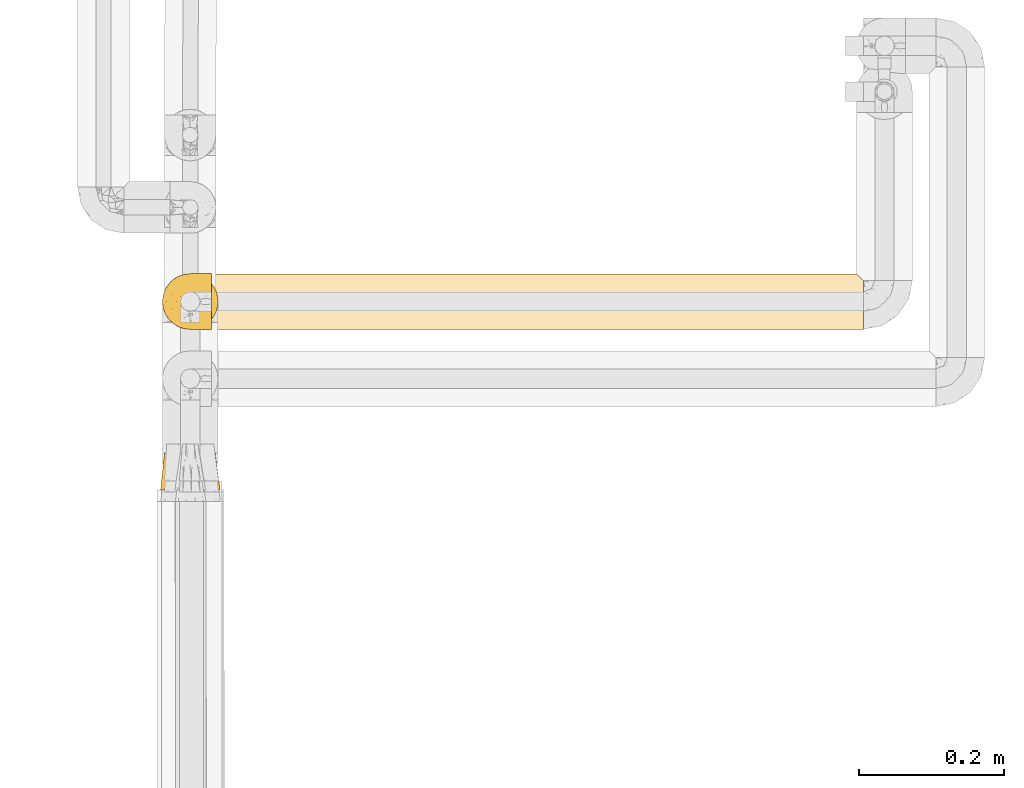
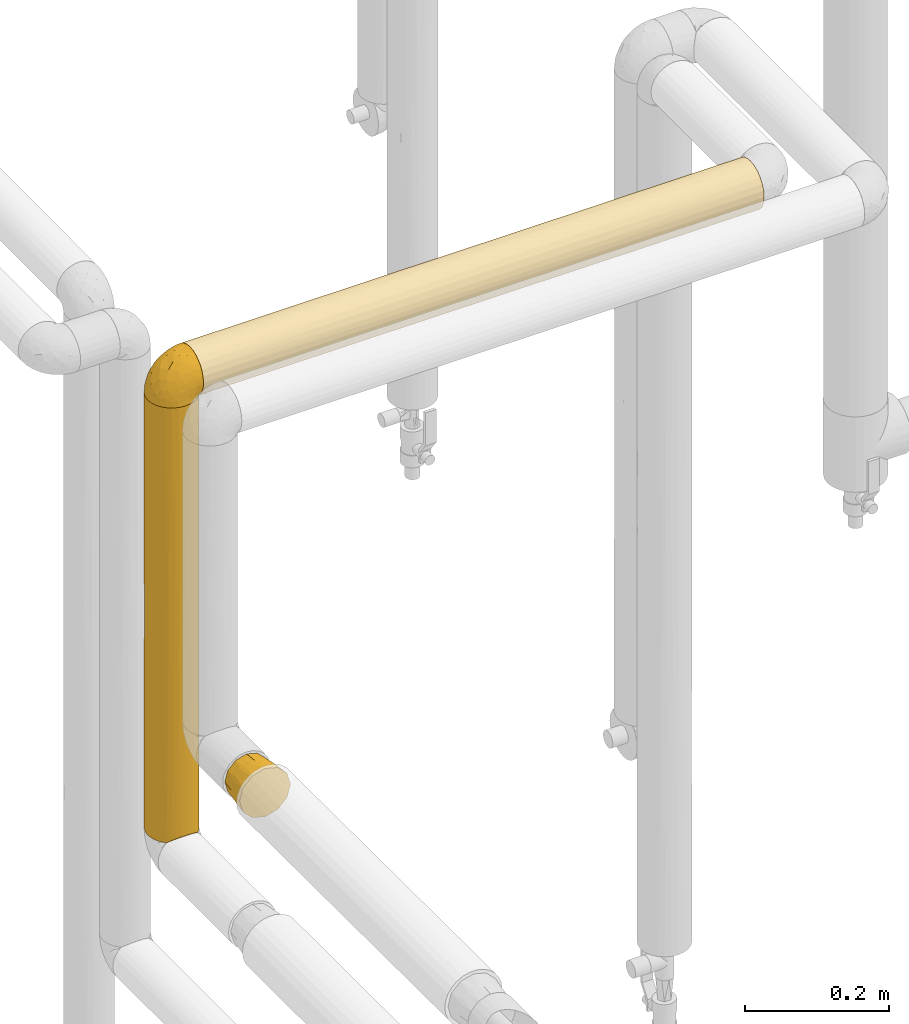
# One storey, part 77 of 827: 4 coverings.
"""IFC2X3 building model written with IfcOpenShell, lengths in millimetres."""

from ifc_helpers import new_model, entity, si_unit, converted_unit, derived_unit, direction, frame, origin, place, context, subcontext, project, spatial, faceted_brep, element, save


model = new_model("IFC2X3")

# Units and contexts
model_context = context("Model", 3, precision=0.01, world=origin(), true_north=direction((6.12303176911189e-17, 1.0)))
body_context = subcontext(model_context, "Body", "Model", "MODEL_VIEW")
ifc_project = project(units=[si_unit("LENGTHUNIT", "METRE", prefix="MILLI"), si_unit("AREAUNIT", "SQUARE_METRE"), si_unit("VOLUMEUNIT", "CUBIC_METRE"), converted_unit("PLANEANGLEUNIT", "DEGREE", entity("IfcRatioMeasure", 0.0174532925199433), si_unit("PLANEANGLEUNIT", "RADIAN"), dimensions=[0, 0, 0, 0, 0, 0, 0]), si_unit("MASSUNIT", "GRAM", prefix="KILO"), derived_unit("MASSDENSITYUNIT", [(si_unit("MASSUNIT", "GRAM", prefix="KILO"), 1), (si_unit("LENGTHUNIT", "METRE"), -3)]), derived_unit("MOMENTOFINERTIAUNIT", [(si_unit("LENGTHUNIT", "METRE"), 4)]), si_unit("TIMEUNIT", "SECOND"), si_unit("FREQUENCYUNIT", "HERTZ"), si_unit("THERMODYNAMICTEMPERATUREUNIT", "DEGREE_CELSIUS"), derived_unit("THERMALTRANSMITTANCEUNIT", [(si_unit("MASSUNIT", "GRAM", prefix="KILO"), 1), (si_unit("THERMODYNAMICTEMPERATUREUNIT", "KELVIN"), -1), (si_unit("TIMEUNIT", "SECOND"), -3)]), derived_unit("VOLUMETRICFLOWRATEUNIT", [(si_unit("LENGTHUNIT", "METRE"), 3), (si_unit("TIMEUNIT", "SECOND"), -1)]), derived_unit("MASSFLOWRATEUNIT", [(si_unit("MASSUNIT", "GRAM", prefix="KILO"), 1), (si_unit("TIMEUNIT", "SECOND"), -1)]), derived_unit("ROTATIONALFREQUENCYUNIT", [(si_unit("TIMEUNIT", "SECOND"), -1)]), si_unit("ELECTRICCURRENTUNIT", "AMPERE"), si_unit("ELECTRICVOLTAGEUNIT", "VOLT"), si_unit("POWERUNIT", "WATT"), si_unit("FORCEUNIT", "NEWTON", prefix="KILO"), si_unit("ILLUMINANCEUNIT", "LUX"), si_unit("LUMINOUSFLUXUNIT", "LUMEN"), si_unit("LUMINOUSINTENSITYUNIT", "CANDELA"), derived_unit("USERDEFINED", [(si_unit("MASSUNIT", "GRAM", prefix="KILO"), -1), (si_unit("LENGTHUNIT", "METRE"), -2), (si_unit("TIMEUNIT", "SECOND"), 3), (si_unit("LUMINOUSFLUXUNIT", "LUMEN"), 1)]), derived_unit("LINEARVELOCITYUNIT", [(si_unit("LENGTHUNIT", "METRE"), 1), (si_unit("TIMEUNIT", "SECOND"), -1)]), si_unit("PRESSUREUNIT", "PASCAL"), derived_unit("USERDEFINED", [(si_unit("LENGTHUNIT", "METRE"), -2), (si_unit("MASSUNIT", "GRAM", prefix="KILO"), 1), (si_unit("TIMEUNIT", "SECOND"), -2)]), derived_unit("LINEARFORCEUNIT", [(si_unit("MASSUNIT", "GRAM", prefix="KILO"), 1), (si_unit("LENGTHUNIT", "METRE"), 1), (si_unit("TIMEUNIT", "SECOND"), -2), (si_unit("LENGTHUNIT", "METRE"), -1)]), derived_unit("PLANARFORCEUNIT", [(si_unit("MASSUNIT", "GRAM", prefix="KILO"), 1), (si_unit("LENGTHUNIT", "METRE"), 1), (si_unit("TIMEUNIT", "SECOND"), -2), (si_unit("LENGTHUNIT", "METRE"), -2)])], contexts=[model_context])

# Site, building, storey
site_placement = place(None, origin())
site = spatial("IfcSite", under=ifc_project, at=site_placement, CompositionType="ELEMENT")
building_placement = place(site_placement, origin())
building = spatial("IfcBuilding", under=site, at=building_placement, CompositionType="ELEMENT")
storey_placement = place(building_placement, frame((0.0, 0.0, 28200.0)))
storey = spatial("IfcBuildingStorey", under=building, at=storey_placement, Name="08", CompositionType="ELEMENT", Elevation=28200.0)

# Coverings
covering_1_placement = place(storey_placement, frame((17884.13, 11605.87, 1305.65)))
element("IfcCovering", 1, at=covering_1_placement, inside=storey, Name=":ADSK_", ObjectType=":ADSK_", PredefinedType="INSULATION", context=body_context, shape_type="Brep", body=[
    faceted_brep([(74.78, 51.25, 51.35), (77.13, 51.26, 42.6), (74.78, 51.25, 33.85), (72.44, 51.24, 25.1), (66.03, 51.22, 18.69), (59.63, 51.2, 12.28), (50.88, 51.17, 9.94), (42.13, 51.14, 7.6), (33.38, 51.11, 9.94), (24.63, 51.08, 12.28), (18.22, 51.06, 18.69), (11.82, 51.04, 25.1), (9.47, 51.03, 33.85), (7.13, 51.02, 42.6), (9.47, 51.03, 51.35), (11.82, 51.04, 60.1), (18.22, 51.06, 66.5), (24.63, 51.08, 72.91), (33.38, 51.11, 75.25), (42.13, 51.14, 77.6), (50.88, 51.17, 75.25), (59.63, 51.2, 72.91), (66.03, 51.22, 66.5), (72.44, 51.24, 60.1), (22.1, 0.07, 78.1), (14.59, 0.04, 70.6), (7.09, 0.02, 63.1), (3.79, 0.01, 50.78), (1.6, 0.0, 42.6), (4.34, 0.01, 32.35), (7.09, 0.02, 22.1), (14.59, 0.04, 14.59), (22.1, 0.07, 7.09), (34.41, 0.11, 3.79), (42.6, 0.14, 1.6), (52.84, 0.17, 4.34), (63.09, 0.21, 7.09), (70.6, 0.23, 14.59), (78.1, 0.26, 22.1), (81.4, 0.27, 34.41), (83.59, 0.28, 42.6), (80.85, 0.27, 52.85), (78.1, 0.26, 63.1), (70.6, 0.23, 70.6), (63.09, 0.21, 78.1), (50.78, 0.17, 81.4), (42.6, 0.14, 83.6), (32.35, 0.1, 80.85), (77.47, 25.76, 28.05), (79.49, 26.9, 35.21), (73.69, 25.75, 21.08), (42.34, 27.62, 4.83), (65.49, 25.72, 12.45), (58.73, 25.69, 8.3), (80.11, 27.75, 42.6), (51.81, 25.67, 5.79), (27.82, 25.59, 7.49), (34.96, 26.75, 5.46), (20.85, 25.57, 11.27), (4.58, 27.51, 42.6), (12.21, 25.54, 19.46), (8.07, 25.52, 26.22), (5.55, 25.51, 33.15), (7.25, 25.52, 57.14), (5.21, 26.65, 49.98), (11.04, 25.53, 64.11), (42.34, 27.64, 80.36), (19.23, 25.56, 72.74), (25.99, 25.58, 76.89), (32.92, 25.61, 79.4), (56.9, 25.69, 77.7), (49.74, 26.8, 79.73), (63.87, 25.71, 73.92), (72.51, 25.74, 65.73), (76.65, 25.76, 58.97), (79.17, 25.76, 52.04)], [[[0, 1, 2, 3, 4, 5, 6, 7, 8, 9, 10, 11, 12, 13, 14, 15, 16, 17, 18, 19, 20, 21, 22, 23]], [[24, 25, 26, 27, 28, 29, 30, 31, 32, 33, 34, 35, 36, 37, 38, 39, 40, 41, 42, 43, 44, 45, 46, 47]], [[39, 48, 49]], [[49, 40, 39]], [[48, 39, 38]], [[3, 2, 48]], [[50, 3, 48]], [[48, 2, 49]], [[51, 7, 6]], [[52, 50, 37]], [[50, 48, 38]], [[5, 52, 53]], [[53, 52, 36]], [[37, 36, 52]], [[50, 38, 37]], [[54, 40, 49, 1]], [[52, 4, 50]], [[4, 3, 50]], [[4, 52, 5]], [[55, 6, 53]], [[53, 35, 55]], [[53, 36, 35]], [[1, 49, 2]], [[6, 5, 53]], [[34, 51, 55]], [[34, 55, 35]], [[51, 6, 55]], [[33, 56, 57]], [[57, 34, 33]], [[56, 33, 32]], [[9, 8, 56]], [[58, 9, 56]], [[56, 8, 57]], [[59, 13, 12]], [[60, 58, 31]], [[58, 56, 32]], [[11, 60, 61]], [[61, 60, 30]], [[31, 30, 60]], [[58, 32, 31]], [[51, 34, 57, 7]], [[60, 10, 58]], [[10, 9, 58]], [[10, 60, 11]], [[62, 12, 61]], [[61, 29, 62]], [[61, 30, 29]], [[7, 57, 8]], [[12, 11, 61]], [[28, 59, 62]], [[28, 62, 29]], [[59, 12, 62]], [[27, 63, 64]], [[64, 28, 27]], [[63, 27, 26]], [[15, 14, 63]], [[65, 15, 63]], [[63, 14, 64]], [[66, 19, 18]], [[67, 65, 25]], [[65, 63, 26]], [[17, 67, 68]], [[68, 67, 24]], [[25, 24, 67]], [[65, 26, 25]], [[59, 28, 64, 13]], [[67, 16, 65]], [[16, 15, 65]], [[16, 67, 17]], [[69, 18, 68]], [[68, 47, 69]], [[68, 24, 47]], [[13, 64, 14]], [[18, 17, 68]], [[46, 66, 69]], [[46, 69, 47]], [[66, 18, 69]], [[45, 70, 71]], [[71, 46, 45]], [[70, 45, 44]], [[21, 20, 70]], [[72, 21, 70]], [[70, 20, 71]], [[54, 1, 0]], [[73, 72, 43]], [[72, 70, 44]], [[23, 73, 74]], [[74, 73, 42]], [[43, 42, 73]], [[72, 44, 43]], [[66, 46, 71, 19]], [[73, 22, 72]], [[22, 21, 72]], [[22, 73, 23]], [[75, 0, 74]], [[74, 41, 75]], [[74, 42, 41]], [[19, 71, 20]], [[0, 23, 74]], [[40, 54, 75]], [[40, 75, 41]], [[54, 0, 75]]]),
])
covering_2_placement = place(storey_placement, frame((17954.23, 11826.18, 1860.0)))
element("IfcCovering", 2, at=covering_2_placement, inside=storey, Name=":ADSK_", ObjectType=":ADSK_", PredefinedType="INSULATION", context=body_context, shape_type="Brep", body=[
    faceted_brep([(1.6, 2.48, 31.79), (1.6, 1.6, 40.0), (1.6, 2.9, 49.93), (1.6, 6.74, 59.2), (1.6, 12.84, 67.15), (1.6, 20.8, 73.25), (1.6, 30.06, 77.09), (1.6, 40.0, 78.4), (1.6, 49.93, 77.09), (1.6, 59.2, 73.25), (1.6, 67.15, 67.15), (1.6, 73.25, 59.2), (1.6, 77.09, 49.93), (1.6, 78.4, 40.0), (1.6, 77.51, 31.79), (1.6, 74.9, 23.98), (1.6, 70.68, 16.91), (1.6, 65.05, 10.9), (1.6, 14.94, 10.9), (1.6, 9.31, 16.91), (1.6, 5.09, 23.98), (902.81, 2.9, 30.06), (902.81, 6.74, 20.8), (902.81, 12.84, 12.84), (902.81, 20.8, 6.74), (902.81, 30.06, 2.9), (902.81, 40.0, 1.6), (902.81, 48.2, 2.48), (902.81, 56.01, 5.09), (902.81, 63.08, 9.31), (902.81, 69.1, 14.94), (902.81, 69.1, 65.05), (902.81, 63.08, 70.68), (902.81, 56.01, 74.9), (902.81, 48.2, 77.51), (902.81, 40.0, 78.4), (902.81, 30.06, 77.09), (902.81, 20.8, 73.25), (902.81, 12.84, 67.15), (902.81, 6.74, 59.2), (902.81, 2.9, 49.93), (902.81, 1.6, 40.0), (893.51, 78.4, 40.0), (894.12, 77.79, 33.21), (677.14, 78.4, 40.0), (10.29, 46.78, 2.2), (227.27, 40.0, 1.6), (10.9, 40.0, 1.6), (447.93, 62.62, 8.97), (214.87, 62.49, 8.87), (325.84, 69.51, 15.43), (335.07, 57.17, 5.65), (5.57, 59.51, 6.92), (671.94, 65.4, 11.2), (454.63, 74.57, 23.28), (639.97, 77.02, 29.8), (712.04, 74.63, 23.41), (637.34, 59.2, 6.74), (895.91, 76.0, 26.63), (645.9, 71.1, 17.48), (217.97, 78.4, 40.0), (339.37, 77.44, 31.47), (460.77, 78.4, 40.0), (619.21, 52.17, 3.58), (443.64, 40.0, 1.6), (317.48, 50.2, 2.98), (229.95, 75.27, 24.81), (898.84, 73.07, 20.48), (673.23, 40.0, 1.6), (8.5, 53.36, 4.0), (686.44, 40.0, 1.6), (625.39, 25.3, 4.52), (696.34, 17.19, 9.1), (612.16, 11.41, 14.36), (332.75, 11.75, 13.98), (455.51, 17.36, 8.97), (565.04, 32.94, 2.25), (340.85, 22.81, 5.65), (317.48, 29.79, 2.98), (8.5, 26.63, 4.0), (10.29, 33.21, 2.2), (662.4, 4.52, 25.3), (218.85, 17.5, 8.87), (5.57, 20.48, 6.92), (326.15, 2.97, 29.81), (560.39, 2.29, 32.72), (686.44, 1.6, 40.0), (434.34, 1.6, 40.0), (217.97, 1.6, 40.0), (432.02, 7.01, 20.33), (200.38, 7.01, 20.33), (452.2, 9.53, 63.37), (203.62, 9.53, 63.37), (296.74, 4.52, 54.69), (617.09, 4.52, 54.69), (700.79, 9.53, 63.37), (284.42, 16.62, 70.46), (329.36, 2.26, 47.1), (560.39, 2.24, 46.99), (607.66, 16.62, 70.46), (414.98, 25.3, 75.47), (623.88, 31.59, 77.46), (344.02, 32.93, 77.74), (652.56, 23.68, 74.76), (204.19, 27.27, 76.22), (686.44, 40.0, 78.4), (217.96, 40.0, 78.4), (470.07, 40.0, 78.4), (235.83, 40.0, 78.4), (704.02, 59.66, 72.98), (638.34, 52.17, 76.41), (563.56, 74.34, 57.18), (279.02, 75.47, 54.69), (448.89, 71.02, 62.63), (472.39, 59.66, 72.98), (321.12, 50.7, 76.87), (571.66, 66.01, 68.24), (894.12, 77.79, 46.78), (586.93, 77.01, 50.2), (237.23, 59.21, 73.24), (292.25, 65.63, 68.58), (685.56, 71.12, 62.49), (339.37, 77.74, 47.05), (895.91, 76.0, 53.36), (208.07, 70.89, 62.8), (898.84, 73.07, 59.51)], [[[0, 1, 2, 3, 4, 5, 6, 7, 8, 9, 10, 11, 12, 13, 14, 15, 16, 17, 18, 19, 20]], [[21, 22, 23, 24, 25, 26, 27, 28, 29, 30, 31, 32, 33, 34, 35, 36, 37, 38, 39, 40, 41]], [[42, 43, 44]], [[45, 46, 47]], [[48, 49, 50]], [[51, 52, 49]], [[53, 30, 29]], [[54, 55, 56]], [[57, 48, 53]], [[55, 43, 58]], [[59, 50, 54]], [[60, 61, 14]], [[44, 55, 62]], [[63, 64, 65]], [[61, 60, 62]], [[58, 56, 55]], [[66, 50, 16]], [[17, 50, 49]], [[67, 30, 59]], [[50, 17, 16]], [[27, 63, 28]], [[63, 65, 51]], [[65, 46, 45]], [[61, 66, 14]], [[52, 17, 49]], [[59, 56, 67]], [[27, 68, 63]], [[69, 65, 45]], [[28, 63, 57]], [[69, 52, 51]], [[14, 13, 60]], [[44, 43, 55]], [[53, 48, 50]], [[51, 49, 48]], [[59, 53, 50]], [[66, 16, 15]], [[61, 55, 54]], [[55, 61, 62]], [[61, 54, 66]], [[51, 48, 57]], [[69, 51, 65]], [[50, 66, 54]], [[14, 66, 15]], [[65, 64, 46]], [[30, 53, 59]], [[29, 28, 57]], [[57, 53, 29]], [[51, 57, 63]], [[67, 56, 58]], [[54, 56, 59]], [[27, 26, 70, 68]], [[68, 64, 63]], [[71, 24, 72]], [[73, 74, 75]], [[76, 64, 68, 70]], [[77, 71, 75]], [[78, 64, 76]], [[78, 79, 80]], [[24, 71, 25]], [[81, 73, 22]], [[79, 78, 77]], [[73, 72, 23]], [[80, 46, 78]], [[82, 18, 83]], [[18, 74, 19]], [[84, 81, 85]], [[83, 79, 77]], [[21, 41, 86]], [[87, 88, 84]], [[89, 73, 81]], [[89, 74, 73]], [[22, 21, 81]], [[90, 20, 19]], [[77, 75, 82]], [[0, 88, 1]], [[0, 20, 84]], [[26, 25, 70]], [[20, 90, 84]], [[82, 74, 18]], [[82, 75, 74]], [[0, 84, 88]], [[74, 89, 90]], [[72, 73, 75]], [[22, 73, 23]], [[74, 90, 19]], [[84, 90, 89]], [[86, 85, 21]], [[84, 89, 81]], [[85, 86, 87]], [[84, 85, 87]], [[21, 85, 81]], [[76, 25, 71]], [[25, 76, 70]], [[78, 76, 71]], [[77, 82, 83]], [[71, 77, 78]], [[71, 72, 75]], [[23, 72, 24]], [[46, 80, 47]], [[46, 64, 78]], [[91, 92, 93, 94, 95]], [[96, 4, 92]], [[97, 98, 93]], [[39, 94, 40]], [[98, 87, 86]], [[38, 95, 39]], [[2, 88, 97]], [[92, 4, 3]], [[3, 2, 93]], [[37, 99, 38]], [[99, 100, 96]], [[100, 101, 102]], [[100, 103, 101]], [[41, 40, 86]], [[88, 2, 1]], [[104, 100, 102]], [[99, 96, 92, 91, 95]], [[5, 4, 96]], [[103, 36, 101]], [[36, 105, 101]], [[106, 7, 6]], [[105, 36, 35]], [[87, 98, 97]], [[100, 104, 96]], [[94, 39, 95]], [[6, 104, 102]], [[98, 40, 94]], [[6, 102, 106]], [[102, 107, 108, 106]], [[103, 100, 99]], [[107, 102, 101]], [[40, 98, 86]], [[93, 98, 94]], [[93, 2, 97]], [[6, 5, 104]], [[88, 87, 97]], [[96, 104, 5]], [[93, 92, 3]], [[99, 95, 38]], [[99, 37, 103]], [[36, 103, 37]], [[105, 107, 101]], [[109, 110, 33]], [[111, 112, 113]], [[114, 115, 110]], [[107, 110, 115]], [[32, 31, 116]], [[117, 44, 118]], [[34, 110, 105]], [[8, 115, 119]], [[114, 116, 120]], [[33, 32, 109]], [[8, 108, 115]], [[116, 31, 121]], [[118, 62, 122]], [[123, 118, 111]], [[120, 10, 119]], [[34, 33, 110]], [[120, 124, 10]], [[118, 123, 117]], [[110, 107, 105]], [[111, 113, 121]], [[11, 124, 112]], [[105, 35, 34]], [[62, 60, 122]], [[112, 12, 11]], [[120, 119, 114]], [[125, 123, 111]], [[125, 121, 31]], [[121, 113, 116]], [[13, 12, 60]], [[120, 116, 113]], [[116, 114, 109]], [[124, 120, 113]], [[119, 10, 9]], [[116, 109, 32]], [[110, 109, 114]], [[122, 12, 112]], [[12, 122, 60]], [[118, 122, 112]], [[111, 121, 125]], [[112, 111, 118]], [[112, 124, 113]], [[10, 124, 11]], [[8, 119, 9]], [[115, 114, 119]], [[44, 117, 42]], [[44, 62, 118]], [[8, 7, 106, 108]], [[108, 107, 115]], [[17, 52, 69, 45, 47, 80, 79, 83, 18]], [[42, 117, 123, 125, 31, 30, 67, 58, 43]]]),
])
covering_3_placement = place(storey_placement, frame((17886.73, 11826.18, 1130.02)))
element("IfcCovering", 3, at=covering_3_placement, inside=storey, Name=":ADSK_", ObjectType=":ADSK_", PredefinedType="INSULATION", context=body_context, shape_type="Brep", body=[
    faceted_brep([(63.08, 9.31, 740.88), (69.1, 14.94, 740.88), (69.1, 65.05, 740.88), (63.08, 70.68, 740.88), (56.01, 74.9, 740.88), (48.2, 77.51, 740.88), (40.0, 78.4, 740.88), (30.06, 77.09, 740.88), (20.8, 73.25, 740.88), (12.84, 67.15, 740.88), (6.74, 59.2, 740.88), (2.9, 49.93, 740.88), (1.6, 40.0, 740.88), (2.9, 30.06, 740.88), (6.74, 20.8, 740.88), (12.84, 12.84, 740.88), (20.8, 6.74, 740.88), (30.06, 2.9, 740.88), (40.0, 1.6, 740.88), (48.2, 2.48, 740.88), (56.01, 5.09, 740.88), (77.09, 49.93, 1.6), (78.4, 40.0, 1.6), (77.51, 31.79, 1.6), (74.9, 23.98, 1.6), (70.68, 16.91, 1.6), (65.05, 10.9, 1.6), (14.94, 10.9, 1.6), (9.31, 16.91, 1.6), (5.09, 23.98, 1.6), (2.48, 31.79, 1.6), (1.6, 40.0, 1.6), (2.9, 49.93, 1.6), (6.74, 59.2, 1.6), (12.84, 67.15, 1.6), (20.8, 73.25, 1.6), (30.06, 77.09, 1.6), (40.0, 78.4, 1.6), (49.93, 77.09, 1.6), (59.2, 73.25, 1.6), (67.15, 67.15, 1.6), (73.25, 59.2, 1.6), (16.62, 70.46, 271.56), (25.3, 75.47, 371.24), (32.5, 77.66, 243.18), (4.52, 54.69, 371.24), (32.5, 77.66, 491.54), (40.0, 78.4, 524.51), (40.0, 78.4, 371.24), (16.62, 70.46, 528.57), (9.53, 63.37, 213.9), (2.33, 47.49, 499.3), (9.53, 63.37, 470.91), (2.33, 47.49, 250.94), (1.6, 40.0, 217.97), (1.6, 40.0, 371.24), (1.6, 40.0, 434.34), (40.0, 78.4, 308.13), (2.89, 30.09, 326.15), (32.8, 2.28, 530.04), (40.0, 1.6, 443.64), (4.32, 25.78, 533.19), (2.2, 33.19, 538.3), (29.79, 2.98, 317.48), (25.3, 4.52, 531.87), (7.01, 20.33, 361.84), (26.63, 4.0, 8.5), (33.21, 2.2, 10.29), (11.72, 14.01, 237.21), (17.41, 8.94, 374.82), (11.58, 14.17, 491.78), (22.8, 5.66, 227.14), (40.0, 1.6, 227.27), (40.0, 1.6, 10.9), (20.48, 6.92, 5.57), (52.17, 3.58, 541.71), (50.2, 2.98, 317.48), (59.51, 6.92, 5.57), (62.57, 8.94, 365.86), (76.55, 28.24, 204.43), (56.49, 5.32, 386.26), (46.78, 2.2, 10.29), (53.36, 4.0, 8.5), (68.03, 13.75, 217.12), (77.51, 31.81, 407.02), (76.0, 26.63, 733.98), (74.59, 23.32, 374.83), (77.79, 33.21, 732.18), (78.4, 40.0, 515.21), (78.4, 40.0, 731.58), (69.44, 15.35, 455.47), (78.4, 40.0, 298.83), (73.07, 20.48, 736.91), (75.47, 54.69, 210.6), (77.79, 46.78, 732.18), (77.71, 47.19, 212.44), (77.01, 50.2, 424.99), (71.05, 62.58, 367.66), (74.33, 57.2, 515.33), (76.0, 53.36, 733.98), (73.07, 59.51, 736.91), (59.66, 72.98, 380.64), (65.82, 68.41, 250.69), (65.98, 68.27, 505.27), (49.9, 77.1, 416.32), (54.21, 75.67, 209.28), (46.8, 77.79, 204.17)], [[[0, 1, 2, 3, 4, 5, 6, 7, 8, 9, 10, 11, 12, 13, 14, 15, 16, 17, 18, 19, 20]], [[21, 22, 23, 24, 25, 26, 27, 28, 29, 30, 31, 32, 33, 34, 35, 36, 37, 38, 39, 40, 41]], [[35, 34, 42]], [[7, 43, 8]], [[36, 35, 43]], [[44, 36, 43]], [[10, 45, 11]], [[46, 6, 47, 48]], [[8, 49, 9]], [[36, 44, 37]], [[42, 49, 43]], [[34, 33, 50]], [[42, 43, 35]], [[51, 12, 11]], [[45, 33, 32]], [[52, 49, 42]], [[43, 49, 8]], [[53, 31, 54, 55, 56, 12, 51]], [[52, 45, 10]], [[50, 45, 52]], [[49, 52, 9]], [[9, 52, 10]], [[45, 51, 11]], [[42, 34, 50]], [[45, 50, 33]], [[42, 50, 52]], [[48, 44, 46]], [[46, 44, 43]], [[44, 48, 57, 37]], [[43, 7, 46]], [[6, 46, 7]], [[53, 51, 45]], [[45, 32, 53]], [[31, 53, 32]], [[30, 29, 58]], [[18, 59, 60]], [[58, 61, 62]], [[59, 63, 60]], [[63, 59, 64]], [[65, 29, 28]], [[66, 67, 63]], [[58, 56, 55, 54]], [[31, 30, 54]], [[68, 65, 28]], [[69, 70, 68]], [[71, 69, 27]], [[69, 68, 27]], [[72, 67, 73]], [[71, 66, 63]], [[14, 65, 70]], [[66, 71, 74]], [[16, 15, 69]], [[67, 72, 63]], [[64, 59, 17]], [[61, 14, 13]], [[69, 71, 64]], [[30, 58, 54]], [[18, 17, 59]], [[17, 16, 64]], [[58, 29, 65]], [[61, 58, 65]], [[71, 27, 74]], [[69, 64, 16]], [[56, 62, 12]], [[72, 60, 63]], [[64, 71, 63]], [[27, 68, 28]], [[70, 69, 15]], [[14, 70, 15]], [[65, 68, 70]], [[14, 61, 65]], [[62, 61, 13]], [[12, 62, 13]], [[58, 62, 56]], [[75, 60, 76]], [[18, 60, 19]], [[77, 26, 78]], [[24, 23, 79]], [[80, 0, 20]], [[80, 77, 78]], [[81, 82, 76]], [[78, 26, 83]], [[72, 81, 76]], [[20, 19, 75]], [[84, 85, 86]], [[20, 75, 80]], [[87, 88, 89]], [[80, 82, 77]], [[0, 78, 90]], [[91, 79, 23]], [[25, 24, 86]], [[80, 78, 0]], [[1, 90, 92]], [[80, 75, 76]], [[80, 76, 82]], [[87, 85, 84]], [[22, 91, 23]], [[90, 1, 0]], [[26, 25, 83]], [[91, 84, 79]], [[87, 84, 88]], [[81, 72, 73]], [[92, 86, 85]], [[79, 84, 86]], [[60, 75, 19]], [[90, 83, 86]], [[24, 79, 86]], [[91, 88, 84]], [[92, 90, 86]], [[86, 83, 25]], [[78, 83, 90]], [[76, 60, 72]], [[93, 21, 41]], [[88, 94, 89]], [[95, 22, 21]], [[96, 95, 93]], [[22, 95, 91]], [[41, 40, 97]], [[93, 97, 98]], [[99, 98, 100]], [[39, 101, 102]], [[98, 99, 96]], [[94, 96, 99]], [[94, 88, 96]], [[2, 100, 98]], [[93, 95, 21]], [[97, 102, 103]], [[97, 93, 41]], [[104, 4, 101]], [[5, 104, 47]], [[105, 104, 101]], [[104, 57, 48, 47]], [[103, 101, 3]], [[3, 101, 4]], [[104, 105, 106]], [[5, 4, 104]], [[5, 47, 6]], [[105, 39, 38]], [[57, 106, 37]], [[2, 97, 103]], [[95, 96, 91]], [[98, 97, 2]], [[88, 91, 96]], [[93, 98, 96]], [[2, 103, 3]], [[102, 97, 40]], [[39, 102, 40]], [[101, 103, 102]], [[39, 105, 101]], [[106, 105, 38]], [[37, 106, 38]], [[104, 106, 57]], [[1, 92, 85, 87, 89, 94, 99, 100, 2]], [[77, 82, 81, 73, 67, 66, 74, 27, 26]]]),
])
covering_4_placement = place(storey_placement, frame((17886.68, 11826.13, 1869.3)))
element("IfcCovering", 4, at=covering_4_placement, inside=storey, Name=":ADSK_", ObjectType=":ADSK_", PredefinedType="INSULATION", context=body_context, shape_type="Brep", body=[
    faceted_brep([(23.36, 5.41, 1.6), (16.07, 9.99, 1.6), (9.98, 16.08, 1.6), (5.4, 23.37, 1.6), (2.56, 31.49, 1.6), (1.6, 40.05, 1.6), (2.56, 48.61, 1.6), (5.41, 56.73, 1.6), (9.99, 64.02, 1.6), (16.08, 70.11, 1.6), (23.37, 74.69, 1.6), (31.49, 77.53, 1.6), (40.05, 78.5, 1.6), (48.15, 77.63, 1.6), (55.88, 75.08, 1.6), (62.9, 70.97, 1.6), (68.89, 65.47, 1.6), (68.89, 63.27, 1.6), (68.89, 61.53, 1.6), (68.89, 59.57, 1.6), (68.89, 57.6, 1.6), (68.89, 55.63, 1.6), (68.89, 53.67, 1.6), (68.89, 51.7, 1.6), (68.89, 49.73, 1.6), (68.89, 47.54, 1.6), (68.89, 45.34, 1.6), (68.89, 43.15, 1.6), (68.89, 40.96, 1.6), (68.89, 38.76, 1.6), (68.89, 36.57, 1.6), (68.89, 34.37, 1.6), (68.89, 32.18, 1.6), (68.89, 29.98, 1.6), (68.89, 27.79, 1.6), (68.89, 25.6, 1.6), (68.89, 23.4, 1.6), (68.89, 21.21, 1.6), (68.89, 19.01, 1.6), (68.89, 16.82, 1.6), (68.89, 14.62, 1.6), (62.89, 9.12, 1.6), (55.86, 5.0, 1.6), (48.13, 2.46, 1.6), (40.05, 1.6, 1.6), (31.49, 2.56, 1.6), (69.15, 65.47, 1.85), (69.15, 70.97, 7.85), (69.15, 75.09, 14.87), (69.15, 77.63, 22.6), (69.15, 78.5, 30.7), (69.15, 77.19, 40.65), (69.15, 73.34, 49.92), (69.15, 67.23, 57.88), (69.15, 59.27, 63.99), (69.15, 50.0, 67.84), (69.15, 40.05, 69.15), (69.15, 30.09, 67.84), (69.15, 20.82, 63.99), (69.15, 12.86, 57.88), (69.15, 6.75, 49.92), (69.15, 2.91, 40.65), (69.15, 1.6, 30.7), (69.15, 2.46, 22.6), (69.15, 5.0, 14.87), (69.15, 9.12, 7.85), (69.15, 14.62, 1.85), (69.15, 16.82, 1.85), (69.15, 17.8, 1.85), (69.15, 19.39, 1.85), (69.15, 20.98, 1.85), (69.15, 22.57, 1.85), (69.15, 24.16, 1.85), (69.15, 25.75, 1.85), (69.15, 27.33, 1.85), (69.15, 28.92, 1.85), (69.15, 30.51, 1.85), (69.15, 32.1, 1.85), (69.15, 33.69, 1.85), (69.15, 35.28, 1.85), (69.15, 36.87, 1.85), (69.15, 38.46, 1.85), (69.15, 40.05, 1.85), (69.15, 41.63, 1.85), (69.15, 43.22, 1.85), (69.15, 44.81, 1.85), (69.15, 46.4, 1.85), (69.15, 47.99, 1.85), (69.15, 49.58, 1.85), (69.15, 51.17, 1.85), (69.15, 52.76, 1.85), (69.15, 54.72, 1.85), (69.15, 56.69, 1.85), (69.15, 58.88, 1.85), (69.15, 61.08, 1.85), (69.15, 63.27, 1.85), (68.96, 37.77, 1.77), (68.97, 36.07, 1.78), (68.97, 32.96, 1.77), (68.97, 31.36, 1.77), (68.95, 56.52, 1.76), (68.96, 54.96, 1.77), (68.98, 18.75, 1.79), (68.97, 58.07, 1.78), (68.97, 50.37, 1.78), (68.98, 23.36, 1.78), (68.97, 24.95, 1.78), (68.97, 42.43, 1.78), (68.94, 15.97, 1.74), (68.98, 51.96, 1.78), (68.98, 53.47, 1.78), (68.96, 48.63, 1.77), (68.97, 63.93, 1.78), (68.98, 40.93, 1.78), (68.98, 29.72, 1.78), (68.97, 62.4, 1.77), (68.96, 60.92, 1.77), (68.97, 17.31, 1.77), (68.97, 21.74, 1.78), (68.98, 34.56, 1.78), (68.96, 20.18, 1.77), (68.97, 14.62, 1.77), (68.94, 14.62, 1.72), (68.92, 14.62, 1.66), (68.97, 65.47, 1.77), (69.02, 65.47, 1.8), (69.08, 65.47, 1.82), (68.98, 59.5, 1.79), (68.97, 47.1, 1.78), (68.98, 45.61, 1.79), (68.97, 28.18, 1.78), (69.08, 14.62, 1.82), (69.02, 14.62, 1.8), (68.96, 26.61, 1.76), (68.92, 65.47, 1.66), (68.94, 65.47, 1.72), (68.97, 39.32, 1.78), (68.96, 44.12, 1.77), (67.02, 72.26, 9.41), (63.33, 76.57, 17.65), (64.61, 71.77, 7.41), (49.27, 78.5, 21.47), (51.4, 77.9, 15.21), (43.94, 78.5, 16.15), (61.87, 78.5, 28.75), (61.54, 75.52, 13.67), (57.95, 76.13, 12.79), (56.12, 77.81, 19.18), (63.4, 78.5, 29.16), (65.41, 72.4, 9.04), (53.1, 76.56, 7.41), (63.04, 71.77, 5.74), (61.33, 72.25, 3.72), (41.99, 78.5, 8.87), (54.6, 78.5, 26.8), (56.6, 75.75, 9.53), (41.58, 78.5, 7.34), (13.72, 50.46, 37.63), (5.82, 52.75, 17.92), (6.74, 40.05, 27.45), (58.82, 77.7, 37.01), (51.58, 77.66, 34.22), (42.09, 71.02, 45.87), (46.12, 63.45, 56.57), (55.56, 70.55, 52.31), (52.38, 75.57, 42.07), (61.54, 75.57, 44.74), (23.76, 72.61, 21.49), (20.5, 72.61, 11.02), (14.64, 67.24, 15.64), (41.77, 77.74, 26.02), (16.28, 57.43, 36.59), (49.4, 47.19, 65.49), (52.34, 54.76, 63.99), (4.3, 40.05, 15.2), (58.67, 63.45, 60.27), (25.26, 60.1, 45.25), (20.17, 63.72, 35.21), (34.7, 76.83, 22.52), (28.67, 76.34, 12.03), (8.62, 60.51, 13.32), (33.37, 72.59, 35.9), (41.35, 76.05, 33.87), (17.15, 66.15, 25.73), (12.68, 60.51, 26.34), (21.47, 51.88, 46.78), (41.11, 55.34, 59.54), (37.53, 48.67, 60.18), (30.64, 53.89, 53.93), (26.66, 46.73, 53.36), (21.38, 40.05, 49.36), (14.06, 40.05, 38.4), (55.54, 40.05, 66.44), (35.17, 63.95, 50.09), (29.04, 67.24, 41.08), (24.34, 69.62, 31.14), (29.33, 73.6, 28.19), (43.3, 40.05, 64.0), (32.34, 40.05, 56.68), (57.75, 4.52, 43.9), (49.41, 32.72, 65.46), (27.85, 27.18, 52.22), (13.7, 29.63, 37.61), (14.63, 12.86, 15.64), (8.61, 19.59, 13.31), (48.85, 9.54, 50.02), (54.13, 16.64, 59.28), (37.84, 17.48, 53.05), (23.75, 7.49, 21.48), (20.49, 7.49, 11.01), (28.66, 3.75, 12.03), (20.83, 20.75, 41.02), (55.15, 2.33, 35.39), (54.6, 1.6, 26.8), (61.87, 1.6, 28.75), (41.58, 1.6, 7.34), (57.58, 26.94, 65.81), (59.91, 9.54, 53.28), (36.94, 31.21, 59.8), (45.72, 25.33, 61.82), (5.82, 27.35, 17.91), (37.91, 8.17, 41.4), (50.18, 4.3, 40.48), (12.67, 19.59, 26.34), (49.29, 2.23, 31.68), (42.64, 2.45, 27.68), (43.94, 1.6, 16.15), (49.27, 1.6, 21.47), (19.45, 12.86, 28.05), (34.7, 3.27, 22.54), (41.99, 1.6, 8.87), (62.29, 2.29, 37.3), (29.01, 12.86, 41.07), (31.47, 6.89, 32.24), (37.18, 12.43, 47.4), (43.45, 4.1, 35.77), (63.33, 3.53, 17.65), (67.23, 6.88, 11.06), (66.07, 8.16, 8.55), (65.22, 9.02, 6.63), (61.99, 5.0, 12.77), (57.95, 3.96, 12.79), (53.09, 3.52, 7.41), (56.84, 2.4, 18.97), (61.33, 7.83, 3.72), (63.06, 8.32, 5.76), (51.41, 2.19, 15.21), (56.61, 4.34, 9.52)], [[[0, 1, 2, 3, 4, 5, 6, 7, 8, 9, 10, 11, 12, 13, 14, 15, 16, 17, 18, 19, 20, 21, 22, 23, 24, 25, 26, 27, 28, 29, 30, 31, 32, 33, 34, 35, 36, 37, 38, 39, 40, 41, 42, 43, 44, 45]], [[46, 47, 48, 49, 50, 51, 52, 53, 54, 55, 56, 57, 58, 59, 60, 61, 62, 63, 64, 65, 66, 67, 68, 69, 70, 71, 72, 73, 74, 75, 76, 77, 78, 79, 80, 81, 82, 83, 84, 85, 86, 87, 88, 89, 90, 91, 92, 93, 94, 95]], [[96, 97, 30]], [[98, 77, 99]], [[100, 101, 21]], [[69, 68, 102]], [[20, 19, 103]], [[24, 23, 104]], [[20, 103, 100]], [[72, 105, 106]], [[84, 83, 107]], [[89, 88, 104]], [[108, 67, 66]], [[109, 110, 90]], [[111, 25, 24]], [[112, 17, 16]], [[82, 113, 83]], [[109, 23, 22]], [[114, 76, 75]], [[105, 36, 106]], [[104, 111, 24]], [[18, 115, 116]], [[97, 96, 80]], [[67, 108, 117]], [[105, 71, 118]], [[31, 97, 119]], [[102, 120, 69]], [[108, 121, 122, 123, 40]], [[112, 95, 115]], [[17, 115, 18]], [[94, 116, 115]], [[117, 68, 67]], [[38, 117, 39]], [[112, 124, 125, 126, 46]], [[17, 112, 115]], [[70, 120, 118]], [[39, 117, 108]], [[120, 38, 37]], [[120, 37, 118]], [[120, 70, 69]], [[116, 94, 127]], [[128, 86, 129]], [[117, 38, 102]], [[74, 130, 75]], [[99, 33, 32]], [[115, 95, 94]], [[39, 108, 40]], [[108, 66, 131, 132, 121]], [[105, 72, 71]], [[118, 37, 36]], [[71, 70, 118]], [[35, 106, 36]], [[36, 105, 118]], [[35, 133, 106]], [[74, 73, 133]], [[106, 133, 73]], [[99, 114, 33]], [[133, 35, 34]], [[73, 72, 106]], [[95, 112, 46]], [[112, 16, 134, 135, 124]], [[130, 114, 75]], [[99, 76, 114]], [[114, 130, 33]], [[34, 33, 130]], [[78, 77, 98]], [[98, 119, 78]], [[130, 133, 34]], [[133, 130, 74]], [[79, 97, 80]], [[98, 99, 32]], [[98, 32, 31]], [[77, 76, 99]], [[97, 79, 119]], [[136, 96, 29]], [[30, 97, 31]], [[136, 29, 28]], [[81, 80, 96]], [[29, 96, 30]], [[31, 119, 98]], [[119, 79, 78]], [[96, 136, 81]], [[82, 81, 136]], [[113, 107, 83]], [[84, 107, 137]], [[107, 27, 137]], [[113, 28, 107]], [[27, 107, 28]], [[85, 84, 137]], [[137, 27, 26]], [[113, 136, 28]], [[136, 113, 82]], [[109, 89, 104]], [[86, 85, 129]], [[89, 109, 90]], [[111, 87, 128]], [[26, 129, 137]], [[88, 111, 104]], [[25, 111, 128]], [[22, 110, 109]], [[23, 109, 104]], [[110, 91, 90]], [[100, 92, 101]], [[110, 22, 101]], [[91, 110, 101]], [[116, 19, 18]], [[111, 88, 87]], [[127, 103, 19]], [[25, 128, 26]], [[86, 128, 87]], [[128, 129, 26]], [[137, 129, 85]], [[120, 102, 38]], [[117, 102, 68]], [[91, 101, 92]], [[21, 101, 22]], [[93, 92, 103]], [[100, 21, 20]], [[100, 103, 92]], [[127, 93, 103]], [[93, 127, 94]], [[116, 127, 19]], [[126, 138, 47]], [[48, 138, 139]], [[140, 125, 124]], [[141, 142, 143]], [[144, 49, 139]], [[145, 140, 146]], [[48, 139, 49]], [[139, 145, 147]], [[49, 144, 148, 50]], [[126, 125, 149]], [[14, 13, 150]], [[151, 146, 140]], [[149, 140, 145]], [[152, 151, 135]], [[152, 14, 150]], [[16, 15, 134]], [[13, 153, 150]], [[124, 151, 140]], [[141, 147, 142]], [[14, 152, 15]], [[15, 152, 134]], [[47, 46, 126]], [[139, 154, 144]], [[138, 48, 47]], [[125, 140, 149]], [[135, 134, 152]], [[146, 155, 142]], [[145, 146, 147]], [[149, 139, 138]], [[147, 141, 154]], [[147, 146, 142]], [[139, 147, 154]], [[139, 149, 145]], [[149, 138, 126]], [[155, 146, 151]], [[150, 143, 142]], [[152, 155, 151]], [[150, 142, 155]], [[13, 12, 156, 153]], [[153, 143, 150]], [[152, 150, 155]], [[151, 124, 135]], [[157, 158, 159]], [[160, 154, 161]], [[162, 163, 164]], [[165, 166, 160]], [[167, 168, 169]], [[141, 170, 161]], [[156, 12, 11]], [[158, 157, 171]], [[172, 55, 173]], [[158, 6, 174]], [[175, 54, 53]], [[52, 166, 164]], [[52, 164, 53]], [[54, 175, 173]], [[166, 52, 51]], [[176, 177, 171]], [[178, 143, 179]], [[156, 11, 179]], [[8, 7, 180]], [[169, 9, 8]], [[179, 143, 153, 156]], [[179, 11, 10]], [[168, 179, 10]], [[181, 162, 182]], [[179, 167, 178]], [[183, 184, 177]], [[183, 169, 184]], [[176, 171, 185]], [[172, 186, 187]], [[158, 7, 6]], [[159, 158, 174]], [[184, 180, 158]], [[54, 173, 55]], [[180, 169, 8]], [[188, 189, 187]], [[9, 168, 10]], [[186, 188, 187]], [[190, 157, 159, 191]], [[55, 172, 192]], [[176, 193, 194]], [[161, 170, 182]], [[162, 164, 165]], [[175, 164, 163]], [[51, 50, 148]], [[167, 195, 196]], [[178, 182, 170]], [[6, 5, 174]], [[158, 180, 7]], [[169, 180, 184]], [[169, 168, 9]], [[179, 168, 167]], [[182, 162, 165]], [[162, 194, 193]], [[161, 165, 160]], [[195, 181, 196]], [[192, 172, 197]], [[192, 56, 55]], [[189, 190, 198]], [[198, 197, 187]], [[172, 187, 197]], [[185, 189, 188]], [[198, 187, 189]], [[186, 172, 173]], [[173, 163, 186]], [[193, 186, 163]], [[176, 185, 188]], [[185, 157, 190]], [[188, 186, 193]], [[177, 176, 194]], [[188, 193, 176]], [[162, 193, 163]], [[195, 177, 194]], [[171, 177, 184]], [[181, 195, 194]], [[183, 167, 169]], [[162, 181, 194]], [[196, 182, 178]], [[158, 171, 184]], [[171, 157, 185]], [[177, 195, 183]], [[167, 183, 195]], [[182, 196, 181]], [[178, 170, 143]], [[178, 167, 196]], [[164, 175, 53]], [[173, 175, 163]], [[160, 51, 148]], [[164, 166, 165]], [[51, 160, 166]], [[160, 148, 144, 154]], [[141, 161, 154]], [[182, 165, 161]], [[190, 189, 185]], [[143, 170, 141]], [[60, 199, 61]], [[197, 200, 192]], [[201, 190, 202]], [[200, 57, 192]], [[203, 204, 2]], [[205, 206, 207]], [[208, 209, 210]], [[211, 207, 201]], [[212, 213, 214]], [[45, 215, 210]], [[216, 206, 58]], [[45, 44, 215]], [[59, 217, 60]], [[60, 217, 199]], [[0, 45, 210]], [[218, 201, 219]], [[202, 159, 220]], [[205, 221, 222]], [[223, 204, 203]], [[1, 203, 2]], [[57, 200, 216]], [[220, 3, 204]], [[220, 174, 4]], [[1, 0, 209]], [[212, 224, 213]], [[225, 226, 227]], [[228, 223, 203]], [[208, 210, 229]], [[210, 226, 229]], [[3, 220, 4]], [[58, 206, 59]], [[209, 203, 1]], [[202, 220, 223]], [[228, 203, 208]], [[202, 211, 201]], [[3, 2, 204]], [[202, 190, 191, 159]], [[210, 215, 230, 226]], [[199, 212, 231]], [[232, 233, 221]], [[233, 208, 229]], [[207, 206, 219]], [[217, 206, 205]], [[227, 224, 225]], [[233, 232, 228]], [[201, 207, 219]], [[234, 232, 221]], [[218, 219, 200]], [[202, 223, 211]], [[174, 220, 159]], [[174, 5, 4]], [[61, 231, 62]], [[220, 204, 223]], [[210, 209, 0]], [[203, 209, 208]], [[225, 233, 229]], [[224, 227, 213]], [[221, 233, 235]], [[57, 56, 192]], [[198, 218, 197]], [[200, 219, 216]], [[201, 198, 190]], [[197, 218, 200]], [[198, 201, 218]], [[206, 216, 219]], [[58, 57, 216]], [[231, 212, 214]], [[222, 212, 199]], [[228, 211, 223]], [[207, 211, 232]], [[62, 231, 214]], [[199, 231, 61]], [[233, 228, 208]], [[211, 228, 232]], [[222, 221, 235]], [[234, 205, 207]], [[206, 217, 59]], [[199, 217, 205]], [[205, 222, 199]], [[224, 222, 235]], [[222, 224, 212]], [[224, 235, 225]], [[233, 225, 235]], [[226, 225, 229]], [[205, 234, 221]], [[207, 232, 234]], [[63, 214, 236]], [[214, 213, 236]], [[214, 63, 62]], [[237, 236, 238]], [[238, 132, 131]], [[236, 237, 64]], [[239, 240, 241]], [[63, 236, 64]], [[131, 66, 65]], [[237, 131, 65]], [[242, 230, 43]], [[237, 65, 64]], [[239, 121, 132]], [[42, 242, 43]], [[241, 240, 243]], [[41, 123, 244]], [[43, 230, 215, 44]], [[244, 122, 245]], [[227, 246, 243]], [[241, 247, 245]], [[121, 239, 245]], [[41, 40, 123]], [[132, 238, 239]], [[244, 42, 41]], [[131, 237, 238]], [[240, 239, 238]], [[245, 239, 241]], [[247, 241, 246]], [[247, 244, 245]], [[238, 236, 240]], [[243, 236, 213]], [[236, 243, 240]], [[227, 226, 246]], [[243, 213, 227]], [[242, 246, 226]], [[243, 246, 241]], [[246, 242, 247]], [[244, 247, 242]], [[242, 226, 230]], [[42, 244, 242]], [[122, 244, 123]], [[122, 121, 245]]]),
])

save(model, "model.ifc")
